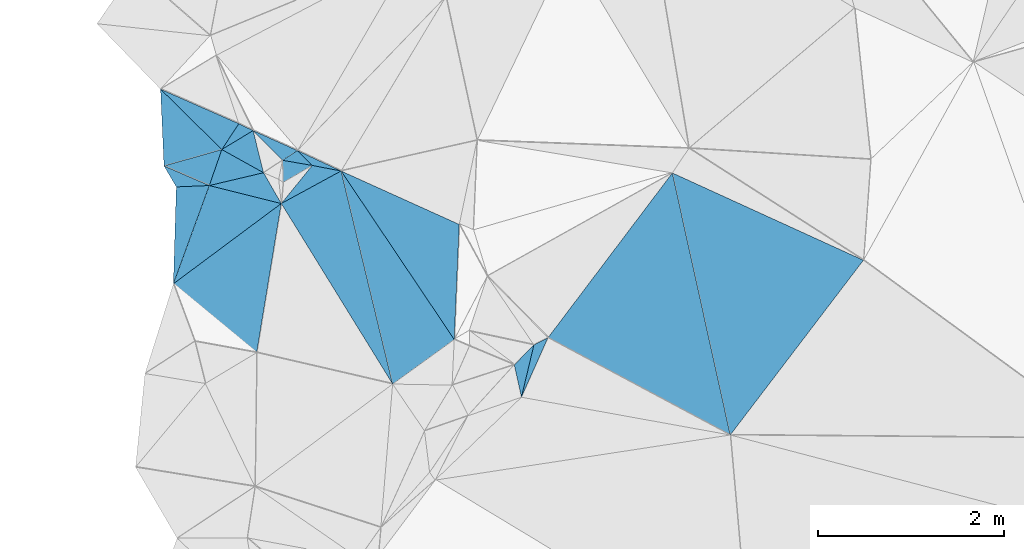
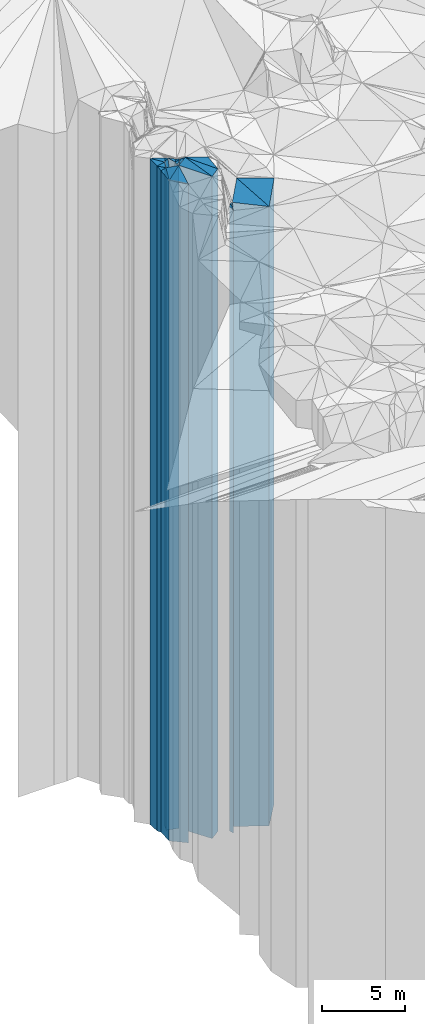
# One storey, part 223 of 275: 23 plates.
"""IFC2X3 building model written with IfcOpenShell, lengths in millimetres."""

from ifc_helpers import new_model, si_unit, frame, origin_with_axes, place, context, subcontext, project, spatial, faceted_brep, material, type_object, element, save


model = new_model("IFC2X3")

# Units and contexts
model_context = context("Model", 3, precision=1e-05, world=origin_with_axes())
body_context = subcontext(model_context, "Body", "Model", "MODEL_VIEW")
ifc_project = project(units=[si_unit("LENGTHUNIT", "METRE", prefix="MILLI"), si_unit("AREAUNIT", "SQUARE_METRE"), si_unit("VOLUMEUNIT", "CUBIC_METRE"), si_unit("MASSUNIT", "GRAM", prefix="KILO"), si_unit("TIMEUNIT", "SECOND"), si_unit("PLANEANGLEUNIT", "RADIAN"), si_unit("SOLIDANGLEUNIT", "STERADIAN"), si_unit("THERMODYNAMICTEMPERATUREUNIT", "DEGREE_CELSIUS"), si_unit("LUMINOUSINTENSITYUNIT", "LUMEN")], contexts=[model_context])

# Site, building, storey
site_placement = place(None, origin_with_axes())
site = spatial("IfcSite", under=ifc_project, at=site_placement, CompositionType="ELEMENT")
building_placement = place(site_placement, origin_with_axes())
building = spatial("IfcBuilding", under=site, at=building_placement, Name="Undefined", CompositionType="ELEMENT")
storey_placement = place(building_placement, origin_with_axes())
storey = spatial("IfcBuildingStorey", under=building, at=storey_placement, Name="Undefined", CompositionType="ELEMENT", Elevation=0.0)

# Plates
ifc_material = material()
plate_type_1 = type_object("IfcPlateType", PredefinedType="NOTDEFINED")
plate_1_placement = place(storey_placement, frame((-138063.812768402, 88529.3426150424, 32024.0), z_axis=(0.999545122437261, -0.0301587170131913, 0.0), x_axis=(-0.0301587170131969, -0.99954512243726, 0.0)))
element("IfcPlate", 1, at=plate_1_placement, inside=storey, type_object=plate_type_1, material=ifc_material, Name="00", context=body_context, shape_type="Brep", body=[
    faceted_brep([(0.0, -24266.0, 0.0), (-25.236019134536, -24356.0, 353.784027099609), (-25.236019134536, 24196.0, 353.784027099609), (2.91038304567337e-11, 24196.0, 1.09139364212751e-11), (1042.16125488281, -24196.0, 5.70435076951981e-09), (1042.16125488281, 24196.0, 5.70435076951981e-09)], [[[0, 1, 2, 3]], [[1, 4, 5, 2]], [[4, 0, 3, 5]], [[5, 3, 2]], [[4, 1, 0]]]),
])
plate_type_2 = type_object("IfcPlateType", PredefinedType="NOTDEFINED")
plate_2_placement = place(storey_placement, frame((-138063.812768402, 88529.3426150424, 32059.0), z_axis=(-0.0410362740138514, 0.999157657336949, 0.0), x_axis=(0.99915765733695, 0.0410362740138193, 0.0)))
element("IfcPlate", 2, at=plate_2_placement, inside=storey, type_object=plate_type_2, material=ifc_material, Name="00", context=body_context, shape_type="Brep", body=[
    faceted_brep([(0.0, -24231.0, 1.45519152283669e-11), (-123.208625793457, -24491.0, 230.910446166992), (-123.208625793457, 24231.0, 230.910446166992), (0.0, 24231.0, 1.45519152283669e-11), (354.682952880859, -24321.0, -8.29459168016911e-10), (354.682952880859, 24231.0, -8.29459168016911e-10)], [[[0, 1, 2, 3]], [[1, 4, 5, 2]], [[4, 0, 3, 5]], [[5, 3, 2]], [[4, 1, 0]]]),
])
plate_type_3 = type_object("IfcPlateType", PredefinedType="NOTDEFINED")
plate_3_placement = place(storey_placement, frame((-137709.428575962, 88543.8974818815, 32024.0), z_axis=(0.939299361014781, -0.3430986890054, 0.0), x_axis=(-0.343098689005404, -0.939299361014779, 0.0)))
element("IfcPlate", 3, at=plate_3_placement, inside=storey, type_object=plate_type_3, material=ifc_material, Name="00", context=body_context, shape_type="Brep", body=[
    faceted_brep([(0.0, -24356.0, 0.0), (-84.0373611450195, -24376.0, 793.686157226592), (-84.0373611450195, 24196.0, 793.686157226592), (2.91038304567337e-11, 24196.0, 1.09139364212751e-11), (1124.49987792968, -24196.0, -8.17817635834217e-09), (1124.49987792968, 24196.0, -8.17817635834217e-09)], [[[0, 1, 2, 3]], [[1, 4, 5, 2]], [[4, 0, 3, 5]], [[5, 3, 2]], [[4, 1, 0]]]),
])
plate_type_4 = type_object("IfcPlateType", PredefinedType="NOTDEFINED")
plate_4_placement = place(storey_placement, frame((-136935.086564512, 88350.5210373407, 32114.0), z_axis=(-0.477955853912095, 0.878383857838451, 0.0), x_axis=(0.878383857838451, 0.477955853912095, 0.0)))
element("IfcPlate", 4, at=plate_4_placement, inside=storey, type_object=plate_type_4, material=ifc_material, Name="00", context=body_context, shape_type="Brep", body=[
    faceted_brep([(0.0, -24286.0, 0.0), (488.080200195313, -24356.0, 200.693115234375), (488.080200195313, 24286.0, 200.693115234375), (0.0, 24286.0, 0.0), (732.461608886719, -24446.0, -5.82076609134674e-11), (732.461608886719, 24286.0, -5.82076609134674e-11)], [[[0, 1, 2, 3]], [[1, 4, 5, 2]], [[4, 0, 3, 5]], [[5, 3, 2]], [[4, 1, 0]]]),
])
plate_type_5 = type_object("IfcPlateType", PredefinedType="NOTDEFINED")
plate_5_placement = place(storey_placement, frame((-136602.287251112, 88760.0874141346, 32144.0), z_axis=(0.188098807986449, 0.98215010992927, 0.0), x_axis=(0.982150109929266, -0.188098807986467, 0.0)))
element("IfcPlate", 5, at=plate_5_placement, inside=storey, type_object=plate_type_5, material=ifc_material, Name="00", context=body_context, shape_type="Brep", body=[
    faceted_brep([(-2.91038304567337e-11, -24326.0, 7.27595761418343e-12), (-185.309463501006, -24316.0, 127.123565673835), (-185.309463501006, 24316.0, 127.123565673835), (-2.91038304567337e-11, 24316.0, 7.27595761418343e-12), (316.227752685518, -24416.0, 1.73167791217566e-09), (316.227752685518, 24316.0, 1.73167791217566e-09)], [[[0, 1, 2, 3]], [[1, 4, 5, 2]], [[4, 0, 3, 5]], [[5, 3, 2]], [[4, 1, 0]]]),
])
plate_type_6 = type_object("IfcPlateType", PredefinedType="NOTDEFINED")
plate_6_placement = place(storey_placement, frame((-136602.287251112, 88760.0874141346, 32094.0), z_axis=(-0.710704225176994, -0.7034909411752, 0.0), x_axis=(-0.703490941175173, 0.710704225177021, 0.0)))
element("IfcPlate", 6, at=plate_6_placement, inside=storey, type_object=plate_type_6, material=ifc_material, Name="00", context=body_context, shape_type="Brep", body=[
    faceted_brep([(2.91038304567337e-11, -24376.0, 2.18278728425503e-11), (264.326538085967, -24266.0, 188.232528686531), (264.326538085967, 24266.0, 188.232528686531), (0.0, 24266.0, 0.0), (224.722045898467, -24366.0, 5.96628524363041e-10), (224.722045898467, 24266.0, 5.96628524363041e-10)], [[[0, 1, 2, 3]], [[1, 4, 5, 2]], [[4, 0, 3, 5]], [[5, 3, 2]], [[4, 1, 0]]]),
])
plate_type_7 = type_object("IfcPlateType", PredefinedType="NOTDEFINED")
plate_7_placement = place(storey_placement, frame((-136922.016224988, 88815.5255171306, 32094.0), z_axis=(-0.542088515014178, 0.840321392021959, 0.0), x_axis=(0.840321392021973, 0.542088515014157, 0.0)))
element("IfcPlate", 7, at=plate_7_placement, inside=storey, type_object=plate_type_7, material=ifc_material, Name="00", context=body_context, shape_type="Brep", body=[
    faceted_brep([(0.0, -24266.0, 0.0), (-92.5377960204933, -24476.0, 439.814453124971), (-92.5377960204933, 24266.0, 439.814453124971), (0.0, 24266.0, 0.0), (192.353836059556, -24366.0, 9.31322574615479e-10), (192.353836059556, 24266.0, 9.31322574615479e-10)], [[[0, 1, 2, 3]], [[1, 4, 5, 2]], [[4, 0, 3, 5]], [[5, 3, 2]], [[4, 1, 0]]]),
])
plate_type_8 = type_object("IfcPlateType", PredefinedType="NOTDEFINED")
plate_8_placement = place(storey_placement, frame((-137238.196078579, 89134.947338839, 32169.0), z_axis=(-0.436964148096435, -0.899478923198513, 0.0), x_axis=(-0.899478923198528, 0.436964148096405, 0.0)))
element("IfcPlate", 8, at=plate_8_placement, inside=storey, type_object=plate_type_8, material=ifc_material, Name="00", context=body_context, shape_type="Brep", body=[
    faceted_brep([(-2.91038304567337e-11, -24401.0, -7.27595761418343e-12), (213.748153686523, -24341.0, 330.017761230461), (213.748153686523, 24341.0, 330.017761230461), (-2.91038304567337e-11, 24341.0, -7.27595761418343e-12), (170.293869018526, -24401.0, 1.29512045532465e-09), (170.293869018526, 24341.0, 1.29512045532465e-09)], [[[0, 1, 2, 3]], [[1, 4, 5, 2]], [[4, 0, 3, 5]], [[5, 3, 2]], [[4, 1, 0]]]),
])
plate_type_9 = type_object("IfcPlateType", PredefinedType="NOTDEFINED")
plate_9_placement = place(storey_placement, frame((-138233.403284189, 89580.5509944589, 32169.0), z_axis=(0.998996613472114, 0.0447857820211717, 0.0), x_axis=(0.0447857820211762, -0.998996613472114, 0.0)))
element("IfcPlate", 9, at=plate_9_placement, inside=storey, type_object=plate_type_9, material=ifc_material, Name="00", context=body_context, shape_type="Brep", body=[
    faceted_brep([(-1.45519152283669e-11, -24461.0, 0.0), (677.898315429673, -24341.0, 629.01025390625), (677.898315429673, 24341.0, 629.01025390625), (-2.91038304567337e-11, 24341.0, -7.27595761418343e-12), (826.377624511704, -24381.0, -1.89174897968769e-09), (826.377624511704, 24341.0, -1.89174897968769e-09)], [[[0, 1, 2, 3]], [[1, 4, 5, 2]], [[4, 0, 3, 5]], [[5, 3, 2]], [[4, 1, 0]]]),
])
plate_type_10 = type_object("IfcPlateType", PredefinedType="NOTDEFINED")
plate_10_placement = place(storey_placement, frame((-137574.663974164, 88931.5035990959, 32169.0), z_axis=(-0.834737610234905, 0.550647911154959, 0.0), x_axis=(0.550647911154933, 0.834737610234923, 0.0)))
element("IfcPlate", 10, at=plate_10_placement, inside=storey, type_object=plate_type_10, material=ifc_material, Name="00", context=body_context, shape_type="Brep", body=[
    faceted_brep([(2.50111042987555e-12, -24341.0, 0.0), (179.05084228513, -24461.0, 907.271057128906), (179.05084228513, 24341.0, 907.271057128906), (-2.91038304567337e-11, 24341.0, -7.27595761418343e-12), (332.866333007815, -24401.0, -4.45288605988026e-09), (332.866333007815, 24341.0, -4.45288605988026e-09)], [[[0, 1, 2, 3]], [[1, 4, 5, 2]], [[4, 0, 3, 5]], [[5, 3, 2]], [[4, 1, 0]]]),
])
plate_type_11 = type_object("IfcPlateType", PredefinedType="NOTDEFINED")
plate_11_placement = place(storey_placement, frame((-132105.759336164, 85860.8225572965, 30514.0), z_axis=(-0.795430751055872, 0.60604448704257, 0.0), x_axis=(0.606044487042568, 0.795430751055873, 0.0)))
element("IfcPlate", 11, at=plate_11_placement, inside=storey, type_object=plate_type_11, material=ifc_material, Name="00", context=body_context, shape_type="Brep", body=[
    faceted_brep([(0.0, -22686.0, 2.91038304567337e-11), (1864.49914550779, -23286.0, 2203.9606933594), (1864.49914550779, 22686.0, 2203.9606933594), (0.0, 22686.0, 1.45519152283669e-11), (2363.15478515624, -23156.0, -1.36496964842081e-08), (2363.15478515624, 22686.0, -1.36496964842081e-08)], [[[0, 1, 2, 3]], [[1, 4, 5, 2]], [[4, 0, 3, 5]], [[5, 3, 2]], [[4, 1, 0]]]),
])
plate_type_12 = type_object("IfcPlateType", PredefinedType="NOTDEFINED")
plate_12_placement = place(storey_placement, frame((-135020.568993707, 88125.5266572387, 32109.0), z_axis=(-0.412192487041468, -0.911096786091669, 0.0), x_axis=(-0.911096786091667, 0.412192487041472, 0.0)))
element("IfcPlate", 12, at=plate_12_placement, inside=storey, type_object=plate_type_12, material=ifc_material, Name="00", context=body_context, shape_type="Brep", body=[
    faceted_brep([(0.0, -24361.0, 7.27595761418343e-12), (-460.803985595674, -24281.0, 1149.89550781252), (-460.803985595674, 24281.0, 1149.89550781252), (0.0, 24281.0, 7.27595761418343e-12), (1395.17028808594, -24451.0, 7.66158336773515e-09), (1395.17028808594, 24281.0, 7.66158336773515e-09)], [[[0, 1, 2, 3]], [[1, 4, 5, 2]], [[4, 0, 3, 5]], [[5, 3, 2]], [[4, 1, 0]]]),
])
plate_type_13 = type_object("IfcPlateType", PredefinedType="NOTDEFINED")
plate_13_placement = place(storey_placement, frame((-136922.016224988, 88815.5255171306, 32064.0), z_axis=(0.999608028283818, 0.0279962460079445, 0.0), x_axis=(0.0279962460079619, -0.999608028283818, 0.0)))
element("IfcPlate", 13, at=plate_13_placement, inside=storey, type_object=plate_type_13, material=ifc_material, Name="00", context=body_context, shape_type="Brep", body=[
    faceted_brep([(-1.45519152283669e-11, -24296.0, 0.0), (64.3675842285156, -24406.0, 318.051605224609), (64.3675842285156, 24236.0, 318.051605224609), (-1.45519152283669e-11, 24236.0, 0.0), (237.697280883789, -24236.0, -1.65891833603382e-09), (237.697280883789, 24236.0, -1.65891833603382e-09)], [[[0, 1, 2, 3]], [[1, 4, 5, 2]], [[4, 0, 3, 5]], [[5, 3, 2]], [[4, 1, 0]]]),
])
plate_type_14 = type_object("IfcPlateType", PredefinedType="NOTDEFINED")
plate_14_placement = place(storey_placement, frame((-137574.663974164, 88931.5035990959, 30939.0), z_axis=(0.944538313397448, -0.328401240138194, 0.0), x_axis=(-0.328401240138219, -0.94453831339744, 0.0)))
element("IfcPlate", 14, at=plate_14_placement, inside=storey, type_object=plate_type_14, material=ifc_material, Name="00", context=body_context, shape_type="Brep", body=[
    faceted_brep([(7.27595761418343e-12, -25571.0, -2.91038304567337e-11), (88.2140045166161, -23111.0, 506.37762451169), (88.2140045166161, 23111.0, 506.37762451169), (7.27595761418343e-12, 23111.0, -2.91038304567337e-11), (410.365692138686, -25441.0, -1.74622982740402e-09), (410.365692138686, 23111.0, -1.74622982740402e-09)], [[[0, 1, 2, 3]], [[1, 4, 5, 2]], [[4, 0, 3, 5]], [[5, 3, 2]], [[4, 1, 0]]]),
])
plate_type_15 = type_object("IfcPlateType", PredefinedType="NOTDEFINED")
plate_15_placement = place(storey_placement, frame((-137125.340502833, 88681.8870569524, 30939.0), z_axis=(-0.970348511564235, -0.241710086891454, 0.0), x_axis=(-0.241710086891453, 0.970348511564235, 0.0)))
element("IfcPlate", 15, at=plate_15_placement, inside=storey, type_object=plate_type_15, material=ifc_material, Name="00", context=body_context, shape_type="Brep", body=[
    faceted_brep([(1.45519152283669e-11, -23111.0, 0.0), (350.82104492189, -25571.0, 375.665527343765), (350.82104492189, 23111.0, 375.665527343765), (7.27595761418343e-12, 23111.0, -2.91038304567337e-11), (466.90469360353, -25631.0, -1.09139364212751e-09), (466.90469360353, 23111.0, -1.09139364212751e-09)], [[[0, 1, 2, 3]], [[1, 4, 5, 2]], [[4, 0, 3, 5]], [[5, 3, 2]], [[4, 1, 0]]]),
])
plate_type_16 = type_object("IfcPlateType", PredefinedType="NOTDEFINED")
plate_16_placement = place(storey_placement, frame((-135737.629989151, 86408.9243361369, 32084.0), z_axis=(-0.585668058180512, 0.81055100124981, 0.0), x_axis=(0.810551001249814, 0.585668058180506, 0.0)))
element("IfcPlate", 16, at=plate_16_placement, inside=storey, type_object=plate_type_16, material=ifc_material, Name="00", context=body_context, shape_type="Brep", body=[
    faceted_brep([(0.0, -24256.0, 1.45519152283669e-11), (893.059020996116, -24476.0, 2182.02783203128), (893.059020996116, 24256.0, 2182.02783203128), (1.45519152283669e-11, 24256.0, 2.91038304567337e-11), (817.863098144539, -24306.0, 9.16770659387112e-09), (817.863098144539, 24256.0, 9.16770659387112e-09)], [[[0, 1, 2, 3]], [[1, 4, 5, 2]], [[4, 0, 3, 5]], [[5, 3, 2]], [[4, 1, 0]]]),
])
plate_type_17 = type_object("IfcPlateType", PredefinedType="NOTDEFINED")
plate_17_placement = place(storey_placement, frame((-132728.88798143, 88679.6007840198, 30514.0), z_axis=(0.798194474838228, -0.602399850877907, 0.0), x_axis=(-0.602399850877913, -0.798194474838224, 0.0)))
element("IfcPlate", 17, at=plate_17_placement, inside=storey, type_object=plate_type_17, material=ifc_material, Name="00", context=body_context, shape_type="Brep", body=[
    faceted_brep([(-1.09139364212751e-11, -23286.0, 0.0), (1874.560546875, -22686.0, 2195.40942382813), (1874.560546875, 22686.0, 2195.40942382813), (0.0, 22686.0, 1.45519152283669e-11), (2220.36035156247, -23046.0, -4.16184775531292e-09), (2220.36035156247, 22686.0, -4.16184775531292e-09)], [[[0, 1, 2, 3]], [[1, 4, 5, 2]], [[4, 0, 3, 5]], [[5, 3, 2]], [[4, 1, 0]]]),
])
plate_type_18 = type_object("IfcPlateType", PredefinedType="NOTDEFINED")
plate_18_placement = place(storey_placement, frame((-137574.663974164, 88931.5035990959, 32104.0), z_axis=(0.273095846888277, -0.961986828606491, 0.0), x_axis=(-0.96198682860649, -0.273095846888283, 0.0)))
element("IfcPlate", 18, at=plate_18_placement, inside=storey, type_object=plate_type_18, material=ifc_material, Name="00", context=body_context, shape_type="Brep", body=[
    faceted_brep([(0.0, -24406.0, -2.91038304567337e-11), (235.495391845703, -24276.0, 336.068328857407), (235.495391845703, 24276.0, 336.068328857407), (-2.00088834390044e-11, 24276.0, 0.0), (646.29711914064, -24446.0, -5.90807758271694e-09), (646.29711914064, 24276.0, -5.90807758271694e-09)], [[[0, 1, 2, 3]], [[1, 4, 5, 2]], [[4, 0, 3, 5]], [[5, 3, 2]], [[4, 1, 0]]]),
])
plate_type_19 = type_object("IfcPlateType", PredefinedType="NOTDEFINED")
plate_19_placement = place(storey_placement, frame((-136935.086564512, 88350.5210373407, 32084.0), z_axis=(0.851143721903792, 0.524932723940659, 0.0), x_axis=(0.52493272394066, -0.851143721903791, 0.0)))
element("IfcPlate", 19, at=plate_19_placement, inside=storey, type_object=plate_type_19, material=ifc_material, Name="00", context=body_context, shape_type="Brep", body=[
    faceted_brep([(1.45519152283669e-11, -24316.0, 0.0), (39.7604370117188, -24476.0, 731.381652832046), (39.7604370117188, 24256.0, 731.381652832046), (1.45519152283669e-11, 24256.0, 2.91038304567337e-11), (2281.16186523438, -24256.0, -5.10772224515677e-09), (2281.16186523438, 24256.0, -5.10772224515677e-09)], [[[0, 1, 2, 3]], [[1, 4, 5, 2]], [[4, 0, 3, 5]], [[5, 3, 2]], [[4, 1, 0]]]),
])
plate_type_20 = type_object("IfcPlateType", PredefinedType="NOTDEFINED")
plate_20_placement = place(storey_placement, frame((-137199.08727807, 86746.7742919844, 31954.0), z_axis=(-0.986720247213502, 0.162428919035145, 0.0), x_axis=(0.162428918061525, 0.986720247373774, 0.0)))
element("IfcPlate", 20, at=plate_20_placement, inside=storey, type_object=plate_type_20, material=ifc_material, Name="00", context=body_context, shape_type="Brep", body=[
    faceted_brep([(0.0, -24126.0, 1.45519152283669e-11), (585.480833969697, -24266.0, 1004.59552001953), (585.480833969697, 24126.0, 1004.59552001953), (0.0, 24126.0, 0.0), (1625.33068847657, -24446.0, -2.06637196242809e-09), (1625.33068847657, 24126.0, -2.06637196242809e-09)], [[[0, 1, 2, 3]], [[1, 4, 5, 2]], [[4, 0, 3, 5]], [[5, 3, 2]], [[4, 1, 0]]]),
])
plate_type_21 = type_object("IfcPlateType", PredefinedType="NOTDEFINED")
plate_21_placement = place(storey_placement, frame((-137125.340502833, 88681.8870569524, 30939.0), z_axis=(0.229918768061814, -0.973209823261632, 0.0), x_axis=(-0.973209823261632, -0.229918768061814, 0.0)))
element("IfcPlate", 21, at=plate_21_placement, inside=storey, type_object=plate_type_21, material=ifc_material, Name="00", context=body_context, shape_type="Brep", body=[
    faceted_brep([(1.45519152283669e-11, -23111.0, 0.0), (-108.96973419188, -25461.0, 366.231628417969), (-108.96973419188, 23111.0, 366.231628417969), (7.27595761418343e-12, 23111.0, -2.91038304567337e-11), (600.166625976563, -25441.0, -6.99947122484446e-09), (600.166625976563, 23111.0, -6.99947122484446e-09)], [[[0, 1, 2, 3]], [[1, 4, 5, 2]], [[4, 0, 3, 5]], [[5, 3, 2]], [[4, 1, 0]]]),
])
plate_type_22 = type_object("IfcPlateType", PredefinedType="NOTDEFINED")
plate_22_placement = place(storey_placement, frame((-134351.950078749, 86267.180955664, 30639.0), z_axis=(-0.913275715040193, 0.407341955017925, 0.0), x_axis=(0.407341955017939, 0.913275715040186, 0.0)))
element("IfcPlate", 22, at=plate_22_placement, inside=storey, type_object=plate_type_22, material=ifc_material, Name="00", context=body_context, shape_type="Brep", body=[
    faceted_brep([(2.91038304567337e-11, -22811.0, -7.27595761418343e-12), (568.104064941403, -22961.0, 106.573005676299), (568.104064941403, 22811.0, 106.573005676299), (0.0, 22811.0, 0.0), (700.927978515629, -22921.0, 3.02679836750031e-09), (700.927978515629, 22811.0, 3.02679836750031e-09)], [[[0, 1, 2, 3]], [[1, 4, 5, 2]], [[4, 0, 3, 5]], [[5, 3, 2]], [[4, 1, 0]]]),
])
plate_type_23 = type_object("IfcPlateType", PredefinedType="NOTDEFINED")
plate_23_placement = place(storey_placement, frame((-134217.868009659, 86829.4282311118, 30639.0), z_axis=(0.710812196261331, -0.70338184625859, 0.0), x_axis=(-0.703381846258601, -0.710812196261321, 0.0)))
element("IfcPlate", 23, at=plate_23_placement, inside=storey, type_object=plate_type_23, material=ifc_material, Name="00", context=body_context, shape_type="Brep", body=[
    faceted_brep([(0.0, -22961.0, 1.45519152283669e-11), (493.963104248029, -22811.0, 300.167358398467), (493.963104248029, 22811.0, 300.167358398467), (0.0, 22811.0, 0.0), (300.832183837872, -22951.0, 2.91038304567337e-11), (300.832183837872, 22811.0, 2.91038304567337e-11)], [[[0, 1, 2, 3]], [[1, 4, 5, 2]], [[4, 0, 3, 5]], [[5, 3, 2]], [[4, 1, 0]]]),
])

save(model, "model.ifc")
